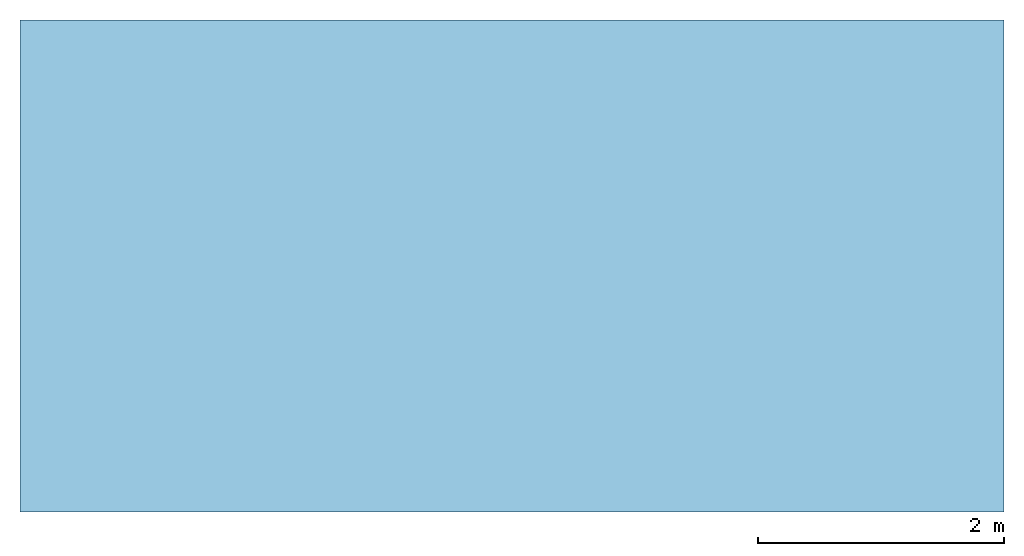
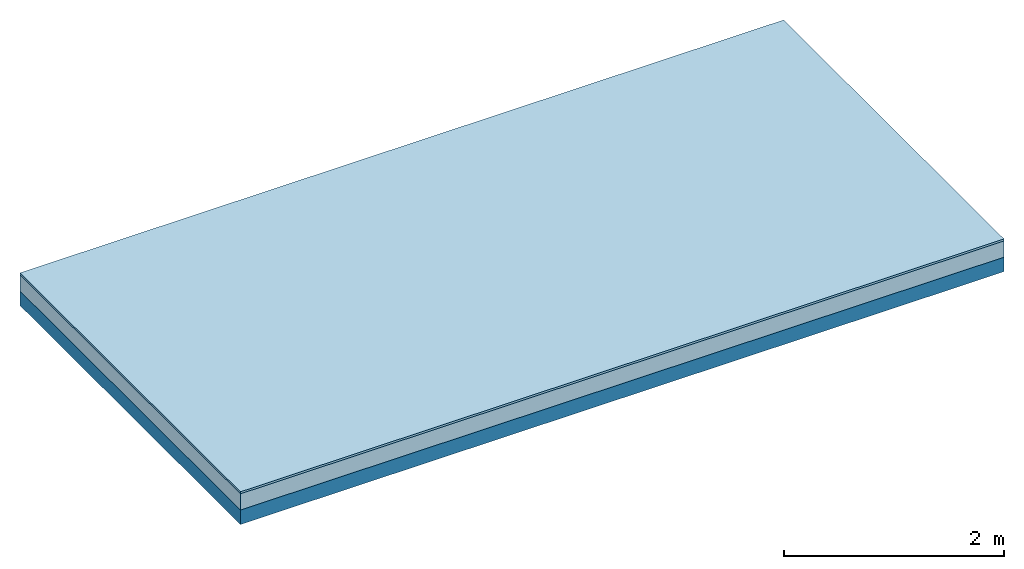
# One storey: 2 plates, 1 member, 1 element without a shape of its own.
"""IFC4 building model written with IfcOpenShell, lengths in metres."""

from ifc_helpers import new_model, si_unit, derived_unit, direction, frame, frame_2d, origin, origin_with_axes, place, context, project, spatial, rectangle, extrude, material, layer, layer_set, type_object, element, aggregate, save


model = new_model("IFC4")

# Units and contexts
plan_context = context("Plan", 3, precision=1e-05, world=origin(), true_north=direction((0.0, 1.0)))
model_context = context("Model", 3, precision=1e-05, world=origin(), true_north=direction((0.0, 1.0)))
ifc_project = project(units=[si_unit("LENGTHUNIT", "METRE"), derived_unit("SOUNDPRESSUREUNIT", [(si_unit("PRESSUREUNIT", "PASCAL", prefix="MICRO"), 0)]), si_unit("ENERGYUNIT", "JOULE", prefix="MEGA"), si_unit("MASSUNIT", "GRAM", prefix="KILO"), derived_unit("THERMALTRANSMITTANCEUNIT", [(si_unit("POWERUNIT", "WATT"), 1), (si_unit("AREAUNIT", "SQUARE_METRE"), -1), (si_unit("THERMODYNAMICTEMPERATUREUNIT", "KELVIN"), -1)]), derived_unit("AREADENSITYUNIT", [(si_unit("MASSUNIT", "GRAM", prefix="KILO"), 1), (si_unit("AREAUNIT", "SQUARE_METRE"), -1)]), derived_unit("USERDEFINED", [(si_unit("ENERGYUNIT", "JOULE", prefix="MEGA"), 1), (si_unit("AREAUNIT", "SQUARE_METRE"), -1)])], contexts=[plan_context, model_context])

# Site, building, storey
site = spatial("IfcSite", under=ifc_project)
building_placement = place(None, origin())
building = spatial("IfcBuilding", under=site, at=building_placement)
storey_placement = place(building_placement, origin())
storey = spatial("IfcBuildingStorey", under=building, at=storey_placement)

# Slab, member, plates
ifc_material_1 = material(Name="OSB3 panel", Category="07.013")
ifc_layer_1 = layer(ifc_material_1, 0.022, Name="On-material")
ifc_material_2 = material()
ifc_layer_2 = layer(ifc_material_2, 0.18, Name="Impact sound insulation")
ifc_material_3 = material(Name="no composite action")
ifc_layer_3 = layer(ifc_material_3, 0.0, Name="Bond")
ifc_layer_4 = layer(None, 0.16, Name="Supporting structure")
ifc_layer_set = layer_set([ifc_layer_1, ifc_layer_2, ifc_layer_3, ifc_layer_4])
slab_type = type_object("IfcSlabType", Name="A2177", PredefinedType="NOTDEFINED", material=ifc_layer_set)
slab_placement = place(None, frame((0.0, 0.0, 0.0), z_axis=(0.0, 0.0, -1.0), x_axis=(1.0, 0.0, 0.0)))
slab = element("IfcSlab", 1, at=slab_placement, inside=storey, type_object=slab_type, material=ifc_layer_set, Name="Slab #1")
ifc_material_4 = material(Name="Solid timber panel")
member_placement = place(slab_placement, origin())
member = element("IfcMember", 2, at=member_placement, material=ifc_material_4, Name="Supporting structure", context=plan_context, shape_type="SweptSolid", body=[
    extrude(rectangle(XDim=1.0, YDim=0.16, at=frame_2d((0.5, 0.08), x_axis=(1.0, 0.0))), frame((0.0, 4.0, 0.202), z_axis=(0.0, -1.0, 0.0), x_axis=(1.0, 0.0, 0.0)), (0.0, 0.0, 1.0), 4.0),
    extrude(rectangle(XDim=1.0, YDim=0.16, at=frame_2d((0.5, 0.08), x_axis=(1.0, 0.0))), frame((1.0, 4.0, 0.202), z_axis=(0.0, -1.0, 0.0), x_axis=(1.0, 0.0, 0.0)), (0.0, 0.0, 1.0), 4.0),
    extrude(rectangle(XDim=1.0, YDim=0.16, at=frame_2d((0.5, 0.08), x_axis=(1.0, 0.0))), frame((2.0, 4.0, 0.202), z_axis=(0.0, -1.0, 0.0), x_axis=(1.0, 0.0, 0.0)), (0.0, 0.0, 1.0), 4.0),
    extrude(rectangle(XDim=1.0, YDim=0.16, at=frame_2d((0.5, 0.08), x_axis=(1.0, 0.0))), frame((3.0, 4.0, 0.202), z_axis=(0.0, -1.0, 0.0), x_axis=(1.0, 0.0, 0.0)), (0.0, 0.0, 1.0), 4.0),
    extrude(rectangle(XDim=1.0, YDim=0.16, at=frame_2d((0.5, 0.08), x_axis=(1.0, 0.0))), frame((4.0, 4.0, 0.202), z_axis=(0.0, -1.0, 0.0), x_axis=(1.0, 0.0, 0.0)), (0.0, 0.0, 1.0), 4.0),
    extrude(rectangle(XDim=1.0, YDim=0.16, at=frame_2d((0.5, 0.08), x_axis=(1.0, 0.0))), frame((5.0, 4.0, 0.202), z_axis=(0.0, -1.0, 0.0), x_axis=(1.0, 0.0, 0.0)), (0.0, 0.0, 1.0), 4.0),
    extrude(rectangle(XDim=1.0, YDim=0.16, at=frame_2d((0.5, 0.08), x_axis=(1.0, 0.0))), frame((6.0, 4.0, 0.202), z_axis=(0.0, -1.0, 0.0), x_axis=(1.0, 0.0, 0.0)), (0.0, 0.0, 1.0), 4.0),
    extrude(rectangle(XDim=1.0, YDim=0.16, at=frame_2d((0.5, 0.08), x_axis=(1.0, 0.0))), frame((7.0, 4.0, 0.202), z_axis=(0.0, -1.0, 0.0), x_axis=(1.0, 0.0, 0.0)), (0.0, 0.0, 1.0), 4.0),
])
plate_1_placement = place(slab_placement, origin())
plate_1 = element("IfcPlate", 3, at=plate_1_placement, material=ifc_material_1, Name="On-material", context=plan_context, shape_type="SweptSolid", body=[
    extrude(rectangle(XDim=8.0, YDim=4.0, at=frame_2d((4.0, 2.0), x_axis=(1.0, 0.0))), origin_with_axes(), (0.0, 0.0, 1.0), 0.022),
])
plate_2_placement = place(slab_placement, origin())
plate_2 = element("IfcPlate", 4, at=plate_2_placement, material=ifc_material_2, Name="Impact sound insulation", context=plan_context, shape_type="SweptSolid", body=[
    extrude(rectangle(XDim=8.0, YDim=4.0, at=frame_2d((4.0, 2.0), x_axis=(1.0, 0.0))), frame((0.0, 0.0, 0.022), z_axis=(0.0, 0.0, 1.0), x_axis=(1.0, 0.0, 0.0)), (0.0, 0.0, 1.0), 0.18),
])
aggregate(slab, [plate_1, plate_2, member])

save(model, "model.ifc")
